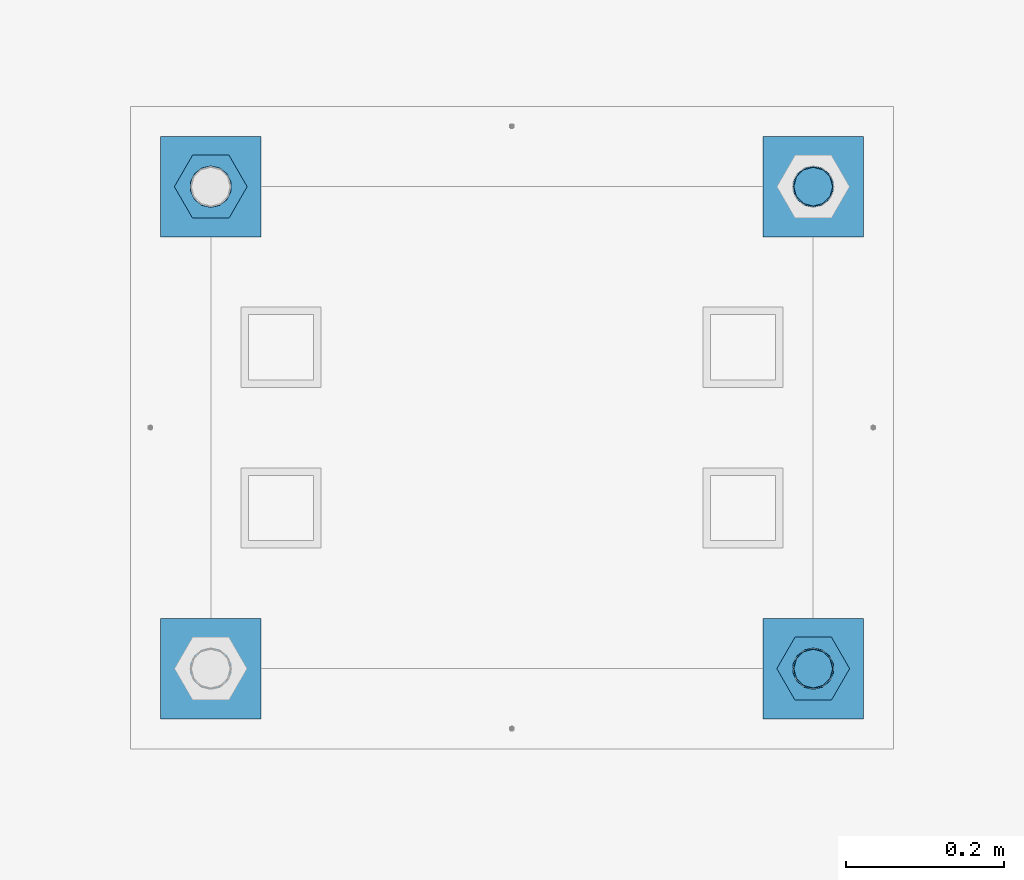
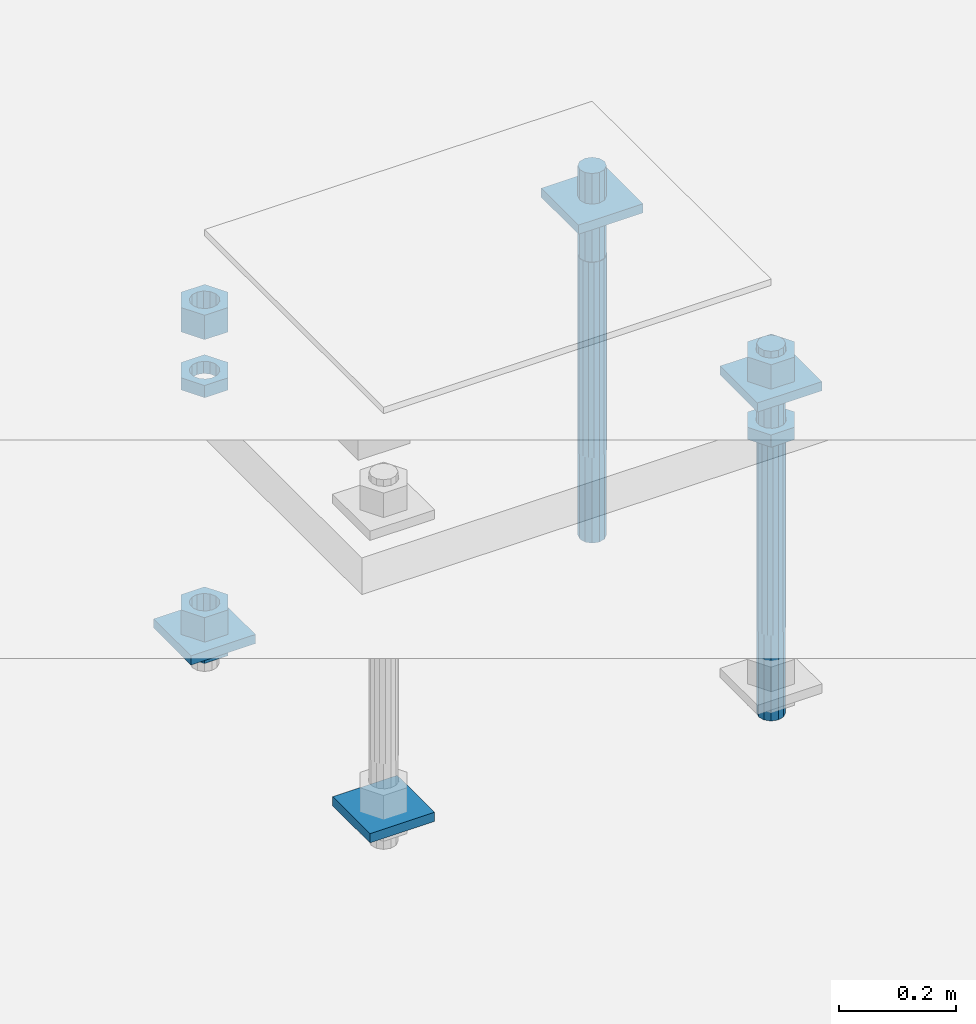
# One storey, part 2604 of 3843: 12 beams, 1 element without a shape of its own.
"""IFC2X3 building model written with IfcOpenShell, lengths in millimetres."""

from ifc_helpers import new_model, si_unit, frame, origin_with_axes, place, context, subcontext, project, spatial, faceted_brep, material, type_object, element, aggregate, save


model = new_model("IFC2X3")

# Units and contexts
model_context = context("Model", 3, precision=1e-05, world=origin_with_axes())
body_context = subcontext(model_context, "Body", "Model", "MODEL_VIEW")
ifc_project = project(units=[si_unit("LENGTHUNIT", "METRE", prefix="MILLI"), si_unit("AREAUNIT", "SQUARE_METRE"), si_unit("VOLUMEUNIT", "CUBIC_METRE"), si_unit("MASSUNIT", "GRAM", prefix="KILO"), si_unit("TIMEUNIT", "SECOND"), si_unit("PLANEANGLEUNIT", "RADIAN"), si_unit("SOLIDANGLEUNIT", "STERADIAN"), si_unit("THERMODYNAMICTEMPERATUREUNIT", "DEGREE_CELSIUS"), si_unit("LUMINOUSINTENSITYUNIT", "LUMEN")], contexts=[model_context])

# Site, building, storey
site_placement = place(None, origin_with_axes())
site = spatial("IfcSite", under=ifc_project, at=site_placement, CompositionType="ELEMENT")
building_placement = place(site_placement, origin_with_axes())
building = spatial("IfcBuilding", under=site, at=building_placement, Name="Undefined", CompositionType="ELEMENT")
storey_placement = place(building_placement, origin_with_axes())
storey = spatial("IfcBuildingStorey", under=building, at=storey_placement, Name="Undefined", CompositionType="ELEMENT", Elevation=0.0)

# Assembly, beams
assembly_placement = place(storey_placement, origin_with_axes())
assembly = element("IfcElementAssembly", 1, at=assembly_placement, inside=storey, Name="TEMPLATE", AssemblyPlace="NOTDEFINED", PredefinedType="RIGID_FRAME")
ifc_material_1 = material(Name="STEEL/A572-50")
beam_type_1 = type_object("IfcBeamType", PredefinedType="NOTDEFINED")
beam_1_placement = place(assembly_placement, frame((105537.0, 24765.0000015259, 29873.575), z_axis=(1.0, 0.0, 0.0), x_axis=(0.0, 1.0, 0.0)))
beam_1 = element("IfcBeam", 2, at=beam_1_placement, type_object=beam_type_1, material=ifc_material_1, Name="WASHER_PLATE", context=body_context, shape_type="Brep", body=[
    faceted_brep([(0.0, 9.52500000000146, -63.5), (0.0, 9.52500000000146, 63.5), (127.0, 9.52500000000146, 63.5), (127.0, 9.52500000000146, -63.5), (0.0, -9.52500000000146, 63.5), (127.0, -9.52500000000146, 63.5), (0.0, -9.52500000000146, -63.5), (127.0, -9.52500000000146, -63.5)], [[[0, 1, 2, 3]], [[1, 4, 5, 2]], [[4, 6, 7, 5]], [[6, 0, 3, 7]], [[5, 7, 3, 2]], [[6, 4, 1, 0]]]),
])
beam_2_placement = place(assembly_placement, frame((105537.0, 25374.6000015259, 29873.575), z_axis=(1.0, 0.0, 0.0), x_axis=(0.0, 1.0, 0.0)))
beam_2 = element("IfcBeam", 3, at=beam_2_placement, type_object=beam_type_1, material=ifc_material_1, Name="WASHER_PLATE", context=body_context, shape_type="Brep", body=[
    faceted_brep([(0.0, 9.52500000000146, -63.5), (0.0, 9.52500000000146, 63.5), (127.0, 9.52500000000146, 63.5), (127.0, 9.52500000000146, -63.5), (0.0, -9.52500000000146, 63.5), (127.0, -9.52500000000146, 63.5), (0.0, -9.52500000000146, -63.5), (127.0, -9.52500000000146, -63.5)], [[[0, 1, 2, 3]], [[1, 4, 5, 2]], [[4, 6, 7, 5]], [[6, 0, 3, 7]], [[5, 7, 3, 2]], [[6, 4, 1, 0]]]),
])
beam_3_placement = place(assembly_placement, frame((104775.0, 24765.0000015259, 29244.925), z_axis=(1.0, 0.0, 0.0), x_axis=(0.0, 1.0, 0.0)))
beam_3 = element("IfcBeam", 4, at=beam_3_placement, type_object=beam_type_1, material=ifc_material_1, Name="WASHER_PLATE", context=body_context, shape_type="Brep", body=[
    faceted_brep([(0.0, 9.52500000000146, -63.5), (0.0, 9.52500000000146, 63.5), (127.0, 9.52500000000146, 63.5), (127.0, 9.52500000000146, -63.5), (0.0, -9.52500000000146, 63.5), (127.0, -9.52500000000146, 63.5), (0.0, -9.52500000000146, -63.5), (127.0, -9.52500000000146, -63.5)], [[[0, 1, 2, 3]], [[1, 4, 5, 2]], [[4, 6, 7, 5]], [[6, 0, 3, 7]], [[5, 7, 3, 2]], [[6, 4, 1, 0]]]),
])
beam_4_placement = place(assembly_placement, frame((104775.0, 25374.6000015259, 29244.925), z_axis=(1.0, 0.0, 0.0), x_axis=(0.0, 1.0, 0.0)))
beam_4 = element("IfcBeam", 5, at=beam_4_placement, type_object=beam_type_1, material=ifc_material_1, Name="WASHER_PLATE", context=body_context, shape_type="Brep", body=[
    faceted_brep([(0.0, 9.52500000000146, -63.5), (0.0, 9.52500000000146, 63.5), (127.0, 9.52500000000146, 63.5), (127.0, 9.52500000000146, -63.5), (0.0, -9.52500000000146, 63.5), (127.0, -9.52500000000146, 63.5), (0.0, -9.52500000000146, -63.5), (127.0, -9.52500000000146, -63.5)], [[[0, 1, 2, 3]], [[1, 4, 5, 2]], [[4, 6, 7, 5]], [[6, 0, 3, 7]], [[5, 7, 3, 2]], [[6, 4, 1, 0]]]),
])
ifc_material_2 = material(Name="STEEL/A36")
beam_type_2 = type_object("IfcBeamType", Name="2_HALF_NUT", PredefinedType="NOTDEFINED")
beam_5_placement = place(assembly_placement, frame((105537.0, 24828.5000015259, 29787.85), z_axis=(0.0, 1.0, 0.0), x_axis=(0.0, 0.0, -1.0)))
beam_5 = element("IfcBeam", 6, at=beam_5_placement, type_object=beam_type_2, material=ifc_material_2, Name="NUT", ObjectType="2_HALF_NUT", context=body_context, shape_type="Brep", body=[
    faceted_brep([(0.0, -46.0369987487793, 0.0), (0.0, -23.0184993743896, -39.869213104248), (25.4000000000015, -23.0184993743896, -39.869213104248), (25.4000000000015, -46.0369987487793, 0.0), (0.0, 23.0184993743896, -39.869213104248), (25.4000000000015, 23.0184993743896, -39.869213104248), (0.0, 46.0369987487793, 0.0), (25.4000000000015, 46.0369987487793, 0.0), (0.0, 23.0184993743896, 39.869213104248), (25.4000000000015, 23.0184993743896, 39.869213104248), (0.0, -23.0184993743896, 39.869213104248), (25.4000000000015, -23.0184993743896, 39.869213104248), (0.0, 0.0, 26.1940002441406), (0.0, 11.3650617044477, 23.5999013092805), (25.4000000000015, 11.3650617044477, 23.5999013092805), (25.4000000000015, 0.0, 26.1940002441406), (0.0, 20.4791109456419, 16.3316083006721), (25.4000000000015, 20.4791109456419, 16.3316083006721), (0.0, 25.5370200498292, 5.82867859874386), (25.4000000000015, 25.5370200498292, 5.82867859874386), (0.0, 25.5370200498292, -5.82867859874386), (25.4000000000015, 25.5370200498292, -5.82867859874386), (0.0, 20.4791109456419, -16.3316083006721), (25.4000000000015, 20.4791109456419, -16.3316083006721), (0.0, 11.3650617044477, -23.5999013092805), (25.4000000000015, 11.3650617044477, -23.5999013092805), (0.0, 0.0, -26.1940002441406), (25.4000000000015, 0.0, -26.1940002441406), (0.0, -11.3650617044477, -23.5999013092805), (25.4000000000015, -11.3650617044477, -23.5999013092805), (0.0, -20.4791109456419, -16.3316083006721), (25.4000000000015, -20.4791109456419, -16.3316083006721), (0.0, -25.5370200498292, -5.82867859874386), (25.4000000000015, -25.5370200498292, -5.82867859874386), (0.0, -25.5370200498292, 5.82867859874386), (25.4000000000015, -25.5370200498292, 5.82867859874386), (0.0, -20.4791109456419, 16.3316083006721), (25.4000000000015, -20.4791109456419, 16.3316083006721), (0.0, -11.3650617044477, 23.5999013092805), (25.4000000000015, -11.3650617044477, 23.5999013092805)], [[[0, 1, 2, 3]], [[1, 4, 5, 2]], [[4, 6, 7, 5]], [[6, 8, 9, 7]], [[8, 10, 11, 9]], [[10, 0, 3, 11]], [[12, 13, 14, 15]], [[13, 16, 17, 14]], [[16, 18, 19, 17]], [[18, 20, 21, 19]], [[20, 22, 23, 21]], [[22, 24, 25, 23]], [[24, 26, 27, 25]], [[26, 28, 29, 27]], [[28, 30, 31, 29]], [[30, 32, 33, 31]], [[32, 34, 35, 33]], [[34, 36, 37, 35]], [[36, 38, 39, 37]], [[38, 12, 15, 39]], [[5, 7, 9, 11, 3, 2], [17, 19, 21, 23, 25, 27, 29, 31, 33, 35, 37, 39, 15, 14]], [[10, 8, 6, 4, 1, 0], [38, 36, 34, 32, 30, 28, 26, 24, 22, 20, 18, 16, 13, 12]]]),
])
beam_6_placement = place(assembly_placement, frame((104775.0, 25438.1000015259, 29787.85), z_axis=(0.0, 1.0, 0.0), x_axis=(0.0, 0.0, -1.0)))
beam_6 = element("IfcBeam", 7, at=beam_6_placement, type_object=beam_type_2, material=ifc_material_2, Name="NUT", ObjectType="2_HALF_NUT", context=body_context, shape_type="Brep", body=[
    faceted_brep([(0.0, -46.0369987487793, 0.0), (0.0, -23.0184993743896, -39.869213104248), (25.4000000000015, -23.0184993743896, -39.869213104248), (25.4000000000015, -46.0369987487793, 0.0), (0.0, 23.0184993743896, -39.869213104248), (25.4000000000015, 23.0184993743896, -39.869213104248), (0.0, 46.0369987487793, 0.0), (25.4000000000015, 46.0369987487793, 0.0), (0.0, 23.0184993743896, 39.869213104248), (25.4000000000015, 23.0184993743896, 39.869213104248), (0.0, -23.0184993743896, 39.869213104248), (25.4000000000015, -23.0184993743896, 39.869213104248), (0.0, 0.0, 26.1940002441406), (0.0, 11.3650617044477, 23.5999013092805), (25.4000000000015, 11.3650617044477, 23.5999013092805), (25.4000000000015, 0.0, 26.1940002441406), (0.0, 20.4791109456419, 16.3316083006721), (25.4000000000015, 20.4791109456419, 16.3316083006721), (0.0, 25.5370200498292, 5.82867859874386), (25.4000000000015, 25.5370200498292, 5.82867859874386), (0.0, 25.5370200498292, -5.82867859874386), (25.4000000000015, 25.5370200498292, -5.82867859874386), (0.0, 20.4791109456419, -16.3316083006721), (25.4000000000015, 20.4791109456419, -16.3316083006721), (0.0, 11.3650617044477, -23.5999013092805), (25.4000000000015, 11.3650617044477, -23.5999013092805), (0.0, 0.0, -26.1940002441406), (25.4000000000015, 0.0, -26.1940002441406), (0.0, -11.3650617044477, -23.5999013092805), (25.4000000000015, -11.3650617044477, -23.5999013092805), (0.0, -20.4791109456419, -16.3316083006721), (25.4000000000015, -20.4791109456419, -16.3316083006721), (0.0, -25.5370200498292, -5.82867859874386), (25.4000000000015, -25.5370200498292, -5.82867859874386), (0.0, -25.5370200498292, 5.82867859874386), (25.4000000000015, -25.5370200498292, 5.82867859874386), (0.0, -20.4791109456419, 16.3316083006721), (25.4000000000015, -20.4791109456419, 16.3316083006721), (0.0, -11.3650617044477, 23.5999013092805), (25.4000000000015, -11.3650617044477, 23.5999013092805)], [[[0, 1, 2, 3]], [[1, 4, 5, 2]], [[4, 6, 7, 5]], [[6, 8, 9, 7]], [[8, 10, 11, 9]], [[10, 0, 3, 11]], [[12, 13, 14, 15]], [[13, 16, 17, 14]], [[16, 18, 19, 17]], [[18, 20, 21, 19]], [[20, 22, 23, 21]], [[22, 24, 25, 23]], [[24, 26, 27, 25]], [[26, 28, 29, 27]], [[28, 30, 31, 29]], [[30, 32, 33, 31]], [[32, 34, 35, 33]], [[34, 36, 37, 35]], [[36, 38, 39, 37]], [[38, 12, 15, 39]], [[5, 7, 9, 11, 3, 2], [17, 19, 21, 23, 25, 27, 29, 31, 33, 35, 37, 39, 15, 14]], [[10, 8, 6, 4, 1, 0], [38, 36, 34, 32, 30, 28, 26, 24, 22, 20, 18, 16, 13, 12]]]),
])
beam_7_placement = place(assembly_placement, frame((104775.0, 25438.1000015259, 29235.4), z_axis=(0.0, 1.0, 0.0), x_axis=(0.0, 0.0, -1.0)))
beam_7 = element("IfcBeam", 8, at=beam_7_placement, type_object=beam_type_2, material=ifc_material_2, Name="NUT", ObjectType="2_HALF_NUT", context=body_context, shape_type="Brep", body=[
    faceted_brep([(0.0, -46.0369987487793, 0.0), (0.0, -23.0184993743896, -39.869213104248), (25.4000000000015, -23.0184993743896, -39.869213104248), (25.4000000000015, -46.0369987487793, 0.0), (0.0, 23.0184993743896, -39.869213104248), (25.4000000000015, 23.0184993743896, -39.869213104248), (0.0, 46.0369987487793, 0.0), (25.4000000000015, 46.0369987487793, 0.0), (0.0, 23.0184993743896, 39.869213104248), (25.4000000000015, 23.0184993743896, 39.869213104248), (0.0, -23.0184993743896, 39.869213104248), (25.4000000000015, -23.0184993743896, 39.869213104248), (0.0, 0.0, 26.1940002441406), (0.0, 11.3650617044477, 23.5999013092805), (25.4000000000015, 11.3650617044477, 23.5999013092805), (25.4000000000015, 0.0, 26.1940002441406), (0.0, 20.4791109456419, 16.3316083006721), (25.4000000000015, 20.4791109456419, 16.3316083006721), (0.0, 25.5370200498292, 5.82867859874386), (25.4000000000015, 25.5370200498292, 5.82867859874386), (0.0, 25.5370200498292, -5.82867859874386), (25.4000000000015, 25.5370200498292, -5.82867859874386), (0.0, 20.4791109456419, -16.3316083006721), (25.4000000000015, 20.4791109456419, -16.3316083006721), (0.0, 11.3650617044477, -23.5999013092805), (25.4000000000015, 11.3650617044477, -23.5999013092805), (0.0, 0.0, -26.1940002441406), (25.4000000000015, 0.0, -26.1940002441406), (0.0, -11.3650617044477, -23.5999013092805), (25.4000000000015, -11.3650617044477, -23.5999013092805), (0.0, -20.4791109456419, -16.3316083006721), (25.4000000000015, -20.4791109456419, -16.3316083006721), (0.0, -25.5370200498292, -5.82867859874386), (25.4000000000015, -25.5370200498292, -5.82867859874386), (0.0, -25.5370200498292, 5.82867859874386), (25.4000000000015, -25.5370200498292, 5.82867859874386), (0.0, -20.4791109456419, 16.3316083006721), (25.4000000000015, -20.4791109456419, 16.3316083006721), (0.0, -11.3650617044477, 23.5999013092805), (25.4000000000015, -11.3650617044477, 23.5999013092805)], [[[0, 1, 2, 3]], [[1, 4, 5, 2]], [[4, 6, 7, 5]], [[6, 8, 9, 7]], [[8, 10, 11, 9]], [[10, 0, 3, 11]], [[12, 13, 14, 15]], [[13, 16, 17, 14]], [[16, 18, 19, 17]], [[18, 20, 21, 19]], [[20, 22, 23, 21]], [[22, 24, 25, 23]], [[24, 26, 27, 25]], [[26, 28, 29, 27]], [[28, 30, 31, 29]], [[30, 32, 33, 31]], [[32, 34, 35, 33]], [[34, 36, 37, 35]], [[36, 38, 39, 37]], [[38, 12, 15, 39]], [[5, 7, 9, 11, 3, 2], [17, 19, 21, 23, 25, 27, 29, 31, 33, 35, 37, 39, 15, 14]], [[10, 8, 6, 4, 1, 0], [38, 36, 34, 32, 30, 28, 26, 24, 22, 20, 18, 16, 13, 12]]]),
])
beam_type_3 = type_object("IfcBeamType", Name="2_HEAVY_HEX_NUT", PredefinedType="NOTDEFINED")
beam_8_placement = place(assembly_placement, frame((105537.0, 24828.5000015259, 29933.9), z_axis=(0.0, 1.0, 0.0), x_axis=(0.0, 0.0, -1.0)))
beam_8 = element("IfcBeam", 9, at=beam_8_placement, type_object=beam_type_3, material=ifc_material_2, Name="NUT", ObjectType="2_HEAVY_HEX_NUT", context=body_context, shape_type="Brep", body=[
    faceted_brep([(0.0, -46.0369987487793, 0.0), (0.0, -23.0184993743896, -39.869213104248), (50.7999999999993, -23.0184993743896, -39.869213104248), (50.7999999999993, -46.0369987487793, 0.0), (0.0, 23.0184993743896, -39.869213104248), (50.7999999999993, 23.0184993743896, -39.869213104248), (0.0, 46.0369987487793, 0.0), (50.7999999999993, 46.0369987487793, 0.0), (0.0, 23.0184993743896, 39.869213104248), (50.7999999999993, 23.0184993743896, 39.869213104248), (0.0, -23.0184993743896, 39.869213104248), (50.7999999999993, -23.0184993743896, 39.869213104248), (0.0, 0.0, 26.1940002441406), (0.0, 11.3650617044477, 23.5999013092805), (50.7999999999993, 11.3650617044477, 23.5999013092805), (50.7999999999993, 0.0, 26.1940002441406), (0.0, 20.4791109456419, 16.3316083006721), (50.7999999999993, 20.4791109456419, 16.3316083006721), (0.0, 25.5370200498292, 5.82867859874386), (50.7999999999993, 25.5370200498292, 5.82867859874386), (0.0, 25.5370200498292, -5.82867859874386), (50.7999999999993, 25.5370200498292, -5.82867859874386), (0.0, 20.4791109456419, -16.3316083006721), (50.7999999999993, 20.4791109456419, -16.3316083006721), (0.0, 11.3650617044477, -23.5999013092805), (50.7999999999993, 11.3650617044477, -23.5999013092805), (0.0, 0.0, -26.1940002441406), (50.7999999999993, 0.0, -26.1940002441406), (0.0, -11.3650617044477, -23.5999013092805), (50.7999999999993, -11.3650617044477, -23.5999013092805), (0.0, -20.4791109456419, -16.3316083006721), (50.7999999999993, -20.4791109456419, -16.3316083006721), (0.0, -25.5370200498292, -5.82867859874386), (50.7999999999993, -25.5370200498292, -5.82867859874386), (0.0, -25.5370200498292, 5.82867859874386), (50.7999999999993, -25.5370200498292, 5.82867859874386), (0.0, -20.4791109456419, 16.3316083006721), (50.7999999999993, -20.4791109456419, 16.3316083006721), (0.0, -11.3650617044477, 23.5999013092805), (50.7999999999993, -11.3650617044477, 23.5999013092805)], [[[0, 1, 2, 3]], [[1, 4, 5, 2]], [[4, 6, 7, 5]], [[6, 8, 9, 7]], [[8, 10, 11, 9]], [[10, 0, 3, 11]], [[12, 13, 14, 15]], [[13, 16, 17, 14]], [[16, 18, 19, 17]], [[18, 20, 21, 19]], [[20, 22, 23, 21]], [[22, 24, 25, 23]], [[24, 26, 27, 25]], [[26, 28, 29, 27]], [[28, 30, 31, 29]], [[30, 32, 33, 31]], [[32, 34, 35, 33]], [[34, 36, 37, 35]], [[36, 38, 39, 37]], [[38, 12, 15, 39]], [[5, 7, 9, 11, 3, 2], [17, 19, 21, 23, 25, 27, 29, 31, 33, 35, 37, 39, 15, 14]], [[10, 8, 6, 4, 1, 0], [38, 36, 34, 32, 30, 28, 26, 24, 22, 20, 18, 16, 13, 12]]]),
])
beam_9_placement = place(assembly_placement, frame((104775.0, 25438.1000015259, 29933.9), z_axis=(0.0, 1.0, 0.0), x_axis=(0.0, 0.0, -1.0)))
beam_9 = element("IfcBeam", 10, at=beam_9_placement, type_object=beam_type_3, material=ifc_material_2, Name="NUT", ObjectType="2_HEAVY_HEX_NUT", context=body_context, shape_type="Brep", body=[
    faceted_brep([(0.0, -46.0369987487793, 0.0), (0.0, -23.0184993743896, -39.869213104248), (50.7999999999993, -23.0184993743896, -39.869213104248), (50.7999999999993, -46.0369987487793, 0.0), (0.0, 23.0184993743896, -39.869213104248), (50.7999999999993, 23.0184993743896, -39.869213104248), (0.0, 46.0369987487793, 0.0), (50.7999999999993, 46.0369987487793, 0.0), (0.0, 23.0184993743896, 39.869213104248), (50.7999999999993, 23.0184993743896, 39.869213104248), (0.0, -23.0184993743896, 39.869213104248), (50.7999999999993, -23.0184993743896, 39.869213104248), (0.0, 0.0, 26.1940002441406), (0.0, 11.3650617044477, 23.5999013092805), (50.7999999999993, 11.3650617044477, 23.5999013092805), (50.7999999999993, 0.0, 26.1940002441406), (0.0, 20.4791109456419, 16.3316083006721), (50.7999999999993, 20.4791109456419, 16.3316083006721), (0.0, 25.5370200498292, 5.82867859874386), (50.7999999999993, 25.5370200498292, 5.82867859874386), (0.0, 25.5370200498292, -5.82867859874386), (50.7999999999993, 25.5370200498292, -5.82867859874386), (0.0, 20.4791109456419, -16.3316083006721), (50.7999999999993, 20.4791109456419, -16.3316083006721), (0.0, 11.3650617044477, -23.5999013092805), (50.7999999999993, 11.3650617044477, -23.5999013092805), (0.0, 0.0, -26.1940002441406), (50.7999999999993, 0.0, -26.1940002441406), (0.0, -11.3650617044477, -23.5999013092805), (50.7999999999993, -11.3650617044477, -23.5999013092805), (0.0, -20.4791109456419, -16.3316083006721), (50.7999999999993, -20.4791109456419, -16.3316083006721), (0.0, -25.5370200498292, -5.82867859874386), (50.7999999999993, -25.5370200498292, -5.82867859874386), (0.0, -25.5370200498292, 5.82867859874386), (50.7999999999993, -25.5370200498292, 5.82867859874386), (0.0, -20.4791109456419, 16.3316083006721), (50.7999999999993, -20.4791109456419, 16.3316083006721), (0.0, -11.3650617044477, 23.5999013092805), (50.7999999999993, -11.3650617044477, 23.5999013092805)], [[[0, 1, 2, 3]], [[1, 4, 5, 2]], [[4, 6, 7, 5]], [[6, 8, 9, 7]], [[8, 10, 11, 9]], [[10, 0, 3, 11]], [[12, 13, 14, 15]], [[13, 16, 17, 14]], [[16, 18, 19, 17]], [[18, 20, 21, 19]], [[20, 22, 23, 21]], [[22, 24, 25, 23]], [[24, 26, 27, 25]], [[26, 28, 29, 27]], [[28, 30, 31, 29]], [[30, 32, 33, 31]], [[32, 34, 35, 33]], [[34, 36, 37, 35]], [[36, 38, 39, 37]], [[38, 12, 15, 39]], [[5, 7, 9, 11, 3, 2], [17, 19, 21, 23, 25, 27, 29, 31, 33, 35, 37, 39, 15, 14]], [[10, 8, 6, 4, 1, 0], [38, 36, 34, 32, 30, 28, 26, 24, 22, 20, 18, 16, 13, 12]]]),
])
beam_10_placement = place(assembly_placement, frame((104775.0, 25438.1000015259, 29305.25), z_axis=(0.0, 1.0, 0.0), x_axis=(0.0, 0.0, -1.0)))
beam_10 = element("IfcBeam", 11, at=beam_10_placement, type_object=beam_type_3, material=ifc_material_2, Name="NUT", ObjectType="2_HEAVY_HEX_NUT", context=body_context, shape_type="Brep", body=[
    faceted_brep([(0.0, -46.0369987487793, 0.0), (0.0, -23.0184993743896, -39.869213104248), (50.7999999999993, -23.0184993743896, -39.869213104248), (50.7999999999993, -46.0369987487793, 0.0), (0.0, 23.0184993743896, -39.869213104248), (50.7999999999993, 23.0184993743896, -39.869213104248), (0.0, 46.0369987487793, 0.0), (50.7999999999993, 46.0369987487793, 0.0), (0.0, 23.0184993743896, 39.869213104248), (50.7999999999993, 23.0184993743896, 39.869213104248), (0.0, -23.0184993743896, 39.869213104248), (50.7999999999993, -23.0184993743896, 39.869213104248), (0.0, 0.0, 26.1940002441406), (0.0, 11.3650617044477, 23.5999013092805), (50.7999999999993, 11.3650617044477, 23.5999013092805), (50.7999999999993, 0.0, 26.1940002441406), (0.0, 20.4791109456419, 16.3316083006721), (50.7999999999993, 20.4791109456419, 16.3316083006721), (0.0, 25.5370200498292, 5.82867859874386), (50.7999999999993, 25.5370200498292, 5.82867859874386), (0.0, 25.5370200498292, -5.82867859874386), (50.7999999999993, 25.5370200498292, -5.82867859874386), (0.0, 20.4791109456419, -16.3316083006721), (50.7999999999993, 20.4791109456419, -16.3316083006721), (0.0, 11.3650617044477, -23.5999013092805), (50.7999999999993, 11.3650617044477, -23.5999013092805), (0.0, 0.0, -26.1940002441406), (50.7999999999993, 0.0, -26.1940002441406), (0.0, -11.3650617044477, -23.5999013092805), (50.7999999999993, -11.3650617044477, -23.5999013092805), (0.0, -20.4791109456419, -16.3316083006721), (50.7999999999993, -20.4791109456419, -16.3316083006721), (0.0, -25.5370200498292, -5.82867859874386), (50.7999999999993, -25.5370200498292, -5.82867859874386), (0.0, -25.5370200498292, 5.82867859874386), (50.7999999999993, -25.5370200498292, 5.82867859874386), (0.0, -20.4791109456419, 16.3316083006721), (50.7999999999993, -20.4791109456419, 16.3316083006721), (0.0, -11.3650617044477, 23.5999013092805), (50.7999999999993, -11.3650617044477, 23.5999013092805)], [[[0, 1, 2, 3]], [[1, 4, 5, 2]], [[4, 6, 7, 5]], [[6, 8, 9, 7]], [[8, 10, 11, 9]], [[10, 0, 3, 11]], [[12, 13, 14, 15]], [[13, 16, 17, 14]], [[16, 18, 19, 17]], [[18, 20, 21, 19]], [[20, 22, 23, 21]], [[22, 24, 25, 23]], [[24, 26, 27, 25]], [[26, 28, 29, 27]], [[28, 30, 31, 29]], [[30, 32, 33, 31]], [[32, 34, 35, 33]], [[34, 36, 37, 35]], [[36, 38, 39, 37]], [[38, 12, 15, 39]], [[5, 7, 9, 11, 3, 2], [17, 19, 21, 23, 25, 27, 29, 31, 33, 35, 37, 39, 15, 14]], [[10, 8, 6, 4, 1, 0], [38, 36, 34, 32, 30, 28, 26, 24, 22, 20, 18, 16, 13, 12]]]),
])
ifc_material_3 = material()
beam_type_4 = type_object("IfcBeamType", PredefinedType="NOTDEFINED")
beam_11_placement = place(assembly_placement, frame((105537.000001526, 25438.1, 29762.45), z_axis=(1.0, 0.0, 0.0), x_axis=(0.0, 0.0, -1.0)))
beam_11 = element("IfcBeam", 12, at=beam_11_placement, type_object=beam_type_4, material=ifc_material_3, Name="ANCHOR_ROD", context=body_context, shape_type="Brep", body=[
    faceted_brep([(0.0, -23.4665401257807, -9.72015918207035), (0.0, -17.9605122421344, -17.9605122421417), (406.399999999998, -17.9605122421344, -17.9605122421417), (406.399999999998, -23.4665401257807, -9.72015918207035), (0.0, -9.72015918207762, -23.466540125788), (406.399999999998, -9.72015918207762, -23.466540125788), (0.0, 0.0, -25.4000000000015), (406.399999999998, 0.0, -25.4000000000015), (0.0, 9.72015918207762, -23.466540125788), (406.399999999998, 9.72015918207762, -23.466540125788), (0.0, 17.9605122421344, -17.9605122421417), (406.399999999998, 17.9605122421344, -17.9605122421417), (0.0, 23.4665401257807, -9.72015918207035), (406.399999999998, 23.4665401257807, -9.72015918207035), (0.0, 25.3999996185303, 0.0), (406.399999999998, 25.3999999999942, 0.0), (0.0, 23.4665401257807, 9.72015918207035), (406.399999999998, 23.4665401257807, 9.72015918207035), (0.0, 17.9605122421344, 17.9605122421417), (406.399999999998, 17.9605122421344, 17.9605122421417), (0.0, 9.72015918207762, 23.466540125788), (406.399999999998, 9.72015918207762, 23.466540125788), (0.0, 0.0, 25.4000000000015), (406.399999999998, 0.0, 25.4000000000015), (0.0, -9.72015918207762, 23.466540125788), (406.399999999998, -9.72015918207762, 23.466540125788), (0.0, -17.9605122421344, 17.9605122421417), (406.399999999998, -17.9605122421344, 17.9605122421417), (0.0, -23.4665401257807, 9.72015918207035), (406.399999999998, -23.4665401257807, 9.72015918207035), (0.0, -25.3999996185303, 0.0), (406.399999999998, -25.3999999999942, 0.0), (584.200000000001, -12.2499999999854, -21.2176223927163), (584.200000000001, 1.45519152283669e-11, -24.5), (584.200000000001, 12.2500000000146, -21.2176223927163), (584.200000000001, 21.2176223927381, -12.25), (584.200000000001, 24.5000000000146, 0.0), (584.200000000001, 21.2176223927381, 12.25), (584.200000000001, 12.2500000000146, 21.2176223927163), (584.200000000001, 1.45519152283669e-11, 24.5), (584.200000000001, -12.2499999999854, 21.2176223927163), (584.200000000001, -21.217622392709, 12.25), (584.200000000001, -24.4999999999854, 0.0), (584.200000000001, -21.217622392709, -12.25), (406.399999999998, -24.4999999999854, 0.0), (406.399999999998, -21.217622392709, -12.25), (406.399999999998, -12.2499999999854, -21.2176223927163), (406.399999999998, 1.45519152283669e-11, -24.5), (406.399999999998, 12.2500000000146, -21.2176223927163), (406.399999999998, 21.2176223927381, -12.25), (406.399999999998, 24.5000000000146, 0.0), (406.399999999998, 21.2176223927381, 12.25), (406.399999999998, 12.2500000000146, 21.2176223927163), (406.399999999998, 1.45519152283669e-11, 24.5), (406.399999999998, -12.2499999999854, 21.2176223927163), (406.399999999998, -21.217622392709, 12.25), (0.0, 12.2500000000146, 21.2176223927163), (0.0, 1.45519152283669e-11, 24.5), (0.0, -12.2499999999854, 21.2176223927163), (0.0, -21.217622392709, 12.25), (0.0, -24.4999999999854, 0.0), (0.0, -21.217622392709, -12.25), (0.0, -12.2499999999854, -21.2176223927163), (0.0, 1.45519152283669e-11, -24.5), (0.0, 12.2500000000146, -21.2176223927163), (0.0, 21.2176223927381, -12.25), (0.0, 24.5000000000146, 0.0), (0.0, 21.2176223927381, 12.25), (-184.150000000001, -21.217622392709, 12.25), (-184.150000000001, -12.2499999999854, 21.2176223927163), (-184.150000000001, 1.45519152283669e-11, 24.5), (-184.150000000001, 12.2500000000146, 21.2176223927163), (-184.150000000001, 21.2176223927381, 12.25), (-184.150000000001, 24.5000000000146, 0.0), (-184.150000000001, 21.2176223927381, -12.25), (-184.150000000001, 12.2500000000146, -21.2176223927163), (-184.150000000001, 1.45519152283669e-11, -24.5), (-184.150000000001, -12.2499999999854, -21.2176223927163), (-184.150000000001, -21.217622392709, -12.25), (-184.150000000001, -24.4999999999854, 0.0)], [[[0, 1, 2, 3]], [[1, 4, 5, 2]], [[4, 6, 7, 5]], [[6, 8, 9, 7]], [[8, 10, 11, 9]], [[10, 12, 13, 11]], [[12, 14, 15, 13]], [[14, 16, 17, 15]], [[16, 18, 19, 17]], [[18, 20, 21, 19]], [[20, 22, 23, 21]], [[22, 24, 25, 23]], [[24, 26, 27, 25]], [[26, 28, 29, 27]], [[28, 30, 31, 29]], [[32, 33, 34, 35, 36, 37, 38, 39, 40, 41, 42, 43]], [[43, 42, 44, 45]], [[32, 43, 45, 46]], [[33, 32, 46, 47]], [[34, 33, 47, 48]], [[35, 34, 48, 49]], [[36, 35, 49, 50]], [[37, 36, 50, 51]], [[38, 37, 51, 52]], [[39, 38, 52, 53]], [[40, 39, 53, 54]], [[41, 40, 54, 55]], [[42, 41, 55, 44]], [[2, 5, 7, 9, 11, 13, 15, 17, 19, 21, 23, 25, 27, 29, 31, 3], [54, 53, 52, 51, 50, 49, 48, 47, 46, 45, 44, 55]], [[30, 0, 3, 31]], [[28, 26, 24, 22, 20, 18, 16, 14, 12, 10, 8, 6, 4, 1, 0, 30], [56, 57, 58, 59, 60, 61, 62, 63, 64, 65, 66, 67]], [[68, 69, 70, 71, 72, 73, 74, 75, 76, 77, 78, 79]], [[71, 70, 57, 56]], [[72, 71, 56, 67]], [[73, 72, 67, 66]], [[74, 73, 66, 65]], [[75, 74, 65, 64]], [[76, 75, 64, 63]], [[77, 76, 63, 62]], [[78, 77, 62, 61]], [[79, 78, 61, 60]], [[68, 79, 60, 59]], [[69, 68, 59, 58]], [[70, 69, 58, 57]]]),
])
beam_12_placement = place(assembly_placement, frame((105537.000001526, 24828.5, 29762.45), z_axis=(1.0, 0.0, 0.0), x_axis=(0.0, 0.0, -1.0)))
beam_12 = element("IfcBeam", 13, at=beam_12_placement, type_object=beam_type_4, material=ifc_material_3, Name="ANCHOR_ROD", context=body_context, shape_type="Brep", body=[
    faceted_brep([(0.0, -23.4665401257807, -9.72015918207035), (0.0, -17.9605122421344, -17.9605122421417), (406.399999999998, -17.9605122421344, -17.9605122421417), (406.399999999998, -23.4665401257807, -9.72015918207035), (0.0, -9.72015918207762, -23.466540125788), (406.399999999998, -9.72015918207762, -23.466540125788), (0.0, 0.0, -25.4000000000015), (406.399999999998, 0.0, -25.4000000000015), (0.0, 9.72015918207762, -23.466540125788), (406.399999999998, 9.72015918207762, -23.466540125788), (0.0, 17.9605122421344, -17.9605122421417), (406.399999999998, 17.9605122421344, -17.9605122421417), (0.0, 23.4665401257807, -9.72015918207035), (406.399999999998, 23.4665401257807, -9.72015918207035), (0.0, 25.3999996185303, 0.0), (406.399999999998, 25.3999999999942, 0.0), (0.0, 23.4665401257807, 9.72015918207035), (406.399999999998, 23.4665401257807, 9.72015918207035), (0.0, 17.9605122421344, 17.9605122421417), (406.399999999998, 17.9605122421344, 17.9605122421417), (0.0, 9.72015918207762, 23.466540125788), (406.399999999998, 9.72015918207762, 23.466540125788), (0.0, 0.0, 25.4000000000015), (406.399999999998, 0.0, 25.4000000000015), (0.0, -9.72015918207762, 23.466540125788), (406.399999999998, -9.72015918207762, 23.466540125788), (0.0, -17.9605122421344, 17.9605122421417), (406.399999999998, -17.9605122421344, 17.9605122421417), (0.0, -23.4665401257807, 9.72015918207035), (406.399999999998, -23.4665401257807, 9.72015918207035), (0.0, -25.3999996185303, 0.0), (406.399999999998, -25.3999999999942, 0.0), (584.200000000001, -12.2499999999854, -21.2176223927163), (584.200000000001, 1.45519152283669e-11, -24.5), (584.200000000001, 12.2500000000146, -21.2176223927163), (584.200000000001, 21.2176223927381, -12.25), (584.200000000001, 24.5000000000146, 0.0), (584.200000000001, 21.2176223927381, 12.25), (584.200000000001, 12.2500000000146, 21.2176223927163), (584.200000000001, 1.45519152283669e-11, 24.5), (584.200000000001, -12.2499999999854, 21.2176223927163), (584.200000000001, -21.217622392709, 12.25), (584.200000000001, -24.4999999999854, 0.0), (584.200000000001, -21.217622392709, -12.25), (406.399999999998, -24.4999999999854, 0.0), (406.399999999998, -21.217622392709, -12.25), (406.399999999998, -12.2499999999854, -21.2176223927163), (406.399999999998, 1.45519152283669e-11, -24.5), (406.399999999998, 12.2500000000146, -21.2176223927163), (406.399999999998, 21.2176223927381, -12.25), (406.399999999998, 24.5000000000146, 0.0), (406.399999999998, 21.2176223927381, 12.25), (406.399999999998, 12.2500000000146, 21.2176223927163), (406.399999999998, 1.45519152283669e-11, 24.5), (406.399999999998, -12.2499999999854, 21.2176223927163), (406.399999999998, -21.217622392709, 12.25), (0.0, 12.2500000000146, 21.2176223927163), (0.0, 1.45519152283669e-11, 24.5), (0.0, -12.2499999999854, 21.2176223927163), (0.0, -21.217622392709, 12.25), (0.0, -24.4999999999854, 0.0), (0.0, -21.217622392709, -12.25), (0.0, -12.2499999999854, -21.2176223927163), (0.0, 1.45519152283669e-11, -24.5), (0.0, 12.2500000000146, -21.2176223927163), (0.0, 21.2176223927381, -12.25), (0.0, 24.5000000000146, 0.0), (0.0, 21.2176223927381, 12.25), (-184.150000000001, -21.217622392709, 12.25), (-184.150000000001, -12.2499999999854, 21.2176223927163), (-184.150000000001, 1.45519152283669e-11, 24.5), (-184.150000000001, 12.2500000000146, 21.2176223927163), (-184.150000000001, 21.2176223927381, 12.25), (-184.150000000001, 24.5000000000146, 0.0), (-184.150000000001, 21.2176223927381, -12.25), (-184.150000000001, 12.2500000000146, -21.2176223927163), (-184.150000000001, 1.45519152283669e-11, -24.5), (-184.150000000001, -12.2499999999854, -21.2176223927163), (-184.150000000001, -21.217622392709, -12.25), (-184.150000000001, -24.4999999999854, 0.0)], [[[0, 1, 2, 3]], [[1, 4, 5, 2]], [[4, 6, 7, 5]], [[6, 8, 9, 7]], [[8, 10, 11, 9]], [[10, 12, 13, 11]], [[12, 14, 15, 13]], [[14, 16, 17, 15]], [[16, 18, 19, 17]], [[18, 20, 21, 19]], [[20, 22, 23, 21]], [[22, 24, 25, 23]], [[24, 26, 27, 25]], [[26, 28, 29, 27]], [[28, 30, 31, 29]], [[32, 33, 34, 35, 36, 37, 38, 39, 40, 41, 42, 43]], [[43, 42, 44, 45]], [[32, 43, 45, 46]], [[33, 32, 46, 47]], [[34, 33, 47, 48]], [[35, 34, 48, 49]], [[36, 35, 49, 50]], [[37, 36, 50, 51]], [[38, 37, 51, 52]], [[39, 38, 52, 53]], [[40, 39, 53, 54]], [[41, 40, 54, 55]], [[42, 41, 55, 44]], [[2, 5, 7, 9, 11, 13, 15, 17, 19, 21, 23, 25, 27, 29, 31, 3], [54, 53, 52, 51, 50, 49, 48, 47, 46, 45, 44, 55]], [[30, 0, 3, 31]], [[28, 26, 24, 22, 20, 18, 16, 14, 12, 10, 8, 6, 4, 1, 0, 30], [56, 57, 58, 59, 60, 61, 62, 63, 64, 65, 66, 67]], [[68, 69, 70, 71, 72, 73, 74, 75, 76, 77, 78, 79]], [[71, 70, 57, 56]], [[72, 71, 56, 67]], [[73, 72, 67, 66]], [[74, 73, 66, 65]], [[75, 74, 65, 64]], [[76, 75, 64, 63]], [[77, 76, 63, 62]], [[78, 77, 62, 61]], [[79, 78, 61, 60]], [[68, 79, 60, 59]], [[69, 68, 59, 58]], [[70, 69, 58, 57]]]),
])
aggregate(assembly, [beam_11, beam_12, beam_1, beam_2, beam_3, beam_5, beam_8, beam_6, beam_9, beam_10, beam_7, beam_4])

save(model, "model.ifc")
